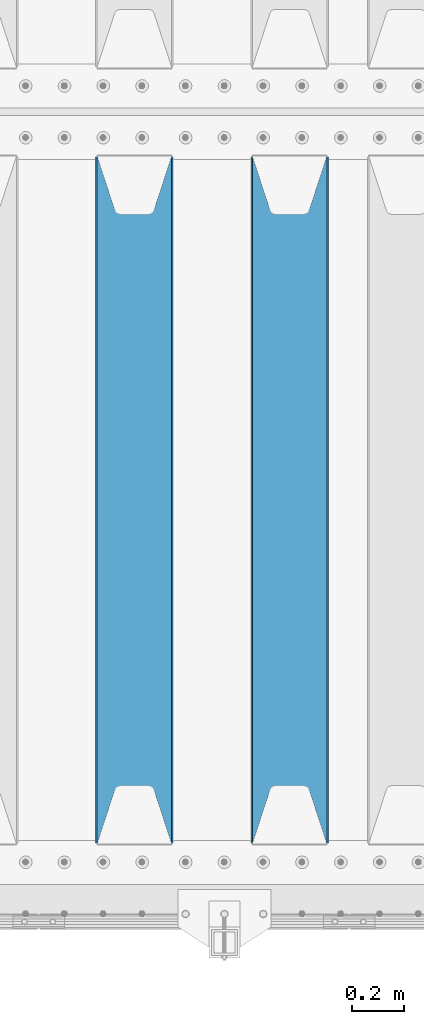
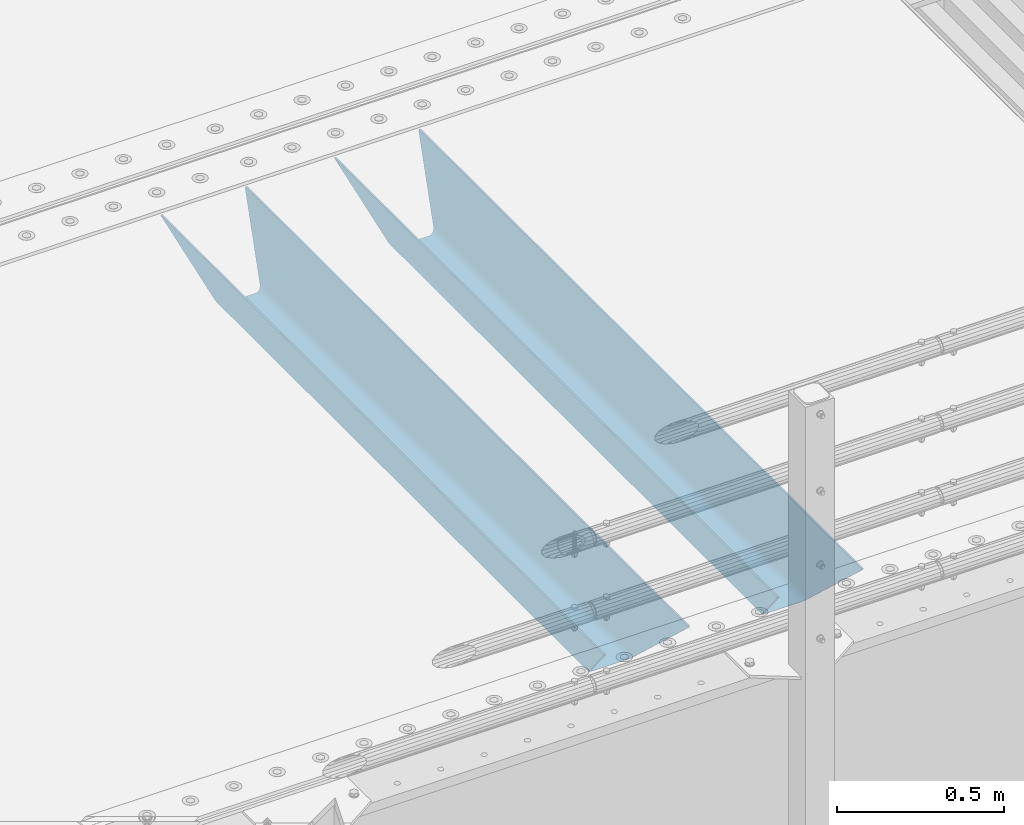
# One storey, part 140 of 270: 2 beams.
"""IFC2X3 building model written with IfcOpenShell, lengths in millimetres."""

import ifcopenshell
import ifcopenshell.guid

model = None  # the IFC model being written
_history = None  # IfcOwnerHistory: only IFC2X3 demands one
_inside = {}  # id of a spatial element -> (the spatial element, [elements in it])
_under = {}  # id of a project, library or spatial element -> (it, [spatial elements below it])
_declared = {}  # id of a project -> (the project, [libraries it declares])
_typed = {}  # id of a type object -> (the type object, [elements of that type])
_made_of = {}  # id of a material, layer set ... -> (it, [elements and type objects made of it])


def new_model(schema):
    """Start an empty IFC model of exactly this schema.

    Asked for "IFC4X3", IfcOpenShell would pick the latest addendum, in which some entities
    have other attributes; the version numbers below select the first issue.
    IFC2X3 requires an IfcOwnerHistory on every rooted entity: one is made here for all.
    """
    global model, _history
    if schema == "IFC4X3":
        model = ifcopenshell.file(schema_version=(4, 3, 0, 0))
    else:
        model = ifcopenshell.file(schema=schema)
    _inside.clear()
    _under.clear()
    _declared.clear()
    _typed.clear()
    _made_of.clear()
    _history = None
    if model.schema == "IFC2X3":
        org = make("IfcOrganization", Name="unknown")
        user = make(
            "IfcPersonAndOrganization",
            ThePerson=make("IfcPerson", FamilyName="unknown"),
            TheOrganization=org,
        )
        app = make(
            "IfcApplication",
            ApplicationDeveloper=org,
            Version="unknown",
            ApplicationFullName="unknown",
            ApplicationIdentifier="unknown",
        )
        _history = make(
            "IfcOwnerHistory",
            OwningUser=user,
            OwningApplication=app,
            ChangeAction="ADDED",
            CreationDate=0,
        )
    return model


def make(cls, **values):
    """One entity of the class cls with the attributes given. An attribute that is None is left unset."""
    return model.create_entity(
        cls, **{name: value for name, value in values.items() if value is not None}
    )


def rooted(cls, **values):
    """An entity with a GlobalId (a new one), such as an element, a storey or a relation."""
    return make(cls, GlobalId=ifcopenshell.guid.new(), OwnerHistory=_history, **values)


def si_unit(unit_type, name, prefix=None):
    """IfcSIUnit, for example si_unit("LENGTHUNIT", "METRE", prefix="MILLI")."""
    return make("IfcSIUnit", UnitType=unit_type, Prefix=prefix, Name=name)


def assignment(units):
    """IfcUnitAssignment: the units of a project."""
    return None if units is None else make("IfcUnitAssignment", Units=units)


def point(xyz):
    """IfcCartesianPoint."""
    return None if xyz is None else make("IfcCartesianPoint", Coordinates=xyz)


def direction(xyz):
    """IfcDirection."""
    return None if xyz is None else make("IfcDirection", DirectionRatios=xyz)


def frame(location, z_axis=None, x_axis=None):
    """IfcAxis2Placement3D, a coordinate frame: its origin and axes. An axis left out is left unset."""
    return make(
        "IfcAxis2Placement3D",
        Location=point(location),
        Axis=direction(z_axis),
        RefDirection=direction(x_axis),
    )


def origin_with_axes():
    """The frame at (0, 0, 0) with the z axis (0, 0, 1) and the x axis (1, 0, 0) written out."""
    return frame((0.0, 0.0, 0.0), z_axis=(0.0, 0.0, 1.0), x_axis=(1.0, 0.0, 0.0))


def place(relative_to, where):
    """IfcLocalPlacement: puts the frame where relative to a parent placement (None: the world)."""
    return make(
        "IfcLocalPlacement", PlacementRelTo=relative_to, RelativePlacement=where
    )


def context(
    kind, dimensions, precision=None, world=None, true_north=None, identifier=None
):
    """IfcGeometricRepresentationContext, for example the 3D "Model" context."""
    return make(
        "IfcGeometricRepresentationContext",
        ContextIdentifier=identifier,
        ContextType=kind,
        CoordinateSpaceDimension=dimensions,
        Precision=precision,
        WorldCoordinateSystem=world,
        TrueNorth=true_north,
    )


def subcontext(parent, identifier, kind, view, scale=None):
    """IfcGeometricRepresentationSubContext, for example "Body" below "Model"."""
    return make(
        "IfcGeometricRepresentationSubContext",
        ContextIdentifier=identifier,
        ContextType=kind,
        ParentContext=parent,
        TargetScale=scale,
        TargetView=view,
    )


def project(units=None, contexts=None):
    """IfcProject with its units and contexts."""
    return rooted(
        "IfcProject",
        Name="project",
        RepresentationContexts=contexts,
        UnitsInContext=assignment(units),
    )


def spatial(cls, under=None, at=None, **own):
    """A site, building, storey or space (cls), placed at a placement, below another one or the project."""
    s = rooted(cls, ObjectPlacement=at, **own)
    if under is not None:
        _under.setdefault(under.id(), (under, []))[1].append(s)
    return s


def faces_of(points, faces, orient=None, outer=None):
    """IfcFace entities. A face is a list of loops; a loop is a list of indices into points, from 0.

    orient and outer hold one flag for each loop. By default every Orientation is true, the
    first loop of a face is its IfcFaceOuterBound and the others are IfcFaceBound.
    """
    made = []
    for i, loops in enumerate(faces):
        bounds = []
        for j, loop in enumerate(loops):
            is_outer = j == 0 if outer is None else outer[i][j]
            bounds.append(
                make(
                    "IfcFaceOuterBound" if is_outer else "IfcFaceBound",
                    Bound=make("IfcPolyLoop", Polygon=[points[k] for k in loop]),
                    Orientation=True if orient is None else orient[i][j],
                )
            )
        made.append(make("IfcFace", Bounds=bounds))
    return made


def faceted_brep(points, faces, orient=None, outer=None, voids=None):
    """IfcFacetedBrep: a solid bounded by flat faces; with voids (closed shells), ...WithVoids."""
    shared = [point(p) for p in points]
    hull = make("IfcClosedShell", CfsFaces=faces_of(shared, faces, orient, outer))
    if voids is None:
        return make("IfcFacetedBrep", Outer=hull)
    return make(
        "IfcFacetedBrepWithVoids",
        Outer=hull,
        Voids=[
            make(cls, CfsFaces=faces_of(shared, fs, o, b)) for cls, fs, o, b in voids
        ],
    )


def shape(context_of_items, identifier, shape_type, items):
    """IfcShapeRepresentation: the items that make up one representation, for example the "Body"."""
    return make(
        "IfcShapeRepresentation",
        ContextOfItems=context_of_items,
        RepresentationIdentifier=identifier,
        RepresentationType=shape_type,
        Items=items,
    )


def material(Name=None, Category=None):
    """IfcMaterial."""
    return make("IfcMaterial", Name=Name, Category=Category)


def made_of(thing, what):
    """Note that an element or type object is made of a material, layer set ...; save() writes the relation."""
    if what is not None:
        _made_of.setdefault(what.id(), (what, []))[1].append(thing)
    return thing


def type_object(cls, material=None, **own):
    """A type object (cls), such as IfcWallType, which elements share."""
    return made_of(rooted(cls, **own), material)


def element(
    cls,
    number,
    at=None,
    inside=None,
    cuts=None,
    type_object=None,
    material=None,
    context=None,
    identifier="Body",
    shape_type=None,
    held_by="IfcProductDefinitionShape",
    body=None,
    shapes=None,
    **own,
):
    """One element of the class cls, such as IfcWall. Its Tag is "e" and its number.

    at: its placement. inside: the storey or other place that contains it. cuts: it is an
    opening in that element (IfcRelVoidsElement). A single representation is given by context,
    identifier, shape_type and body (its items); several are given by shapes. held_by: the class
    of the entity that holds the representations. save() writes the other relations.
    """
    e = rooted(cls, Tag="e%d" % number, ObjectPlacement=at, **own)
    if body is not None:
        shapes = [shape(context, identifier, shape_type, body)]
    if shapes is not None:
        e.Representation = make(held_by, Representations=shapes)
    if inside is not None:
        _inside.setdefault(inside.id(), (inside, []))[1].append(e)
    if cuts is not None:
        rooted(
            "IfcRelVoidsElement", RelatingBuildingElement=cuts, RelatedOpeningElement=e
        )
    if type_object is not None:
        _typed.setdefault(type_object.id(), (type_object, []))[1].append(e)
    return made_of(e, material)


def aggregate(whole, parts):
    """IfcRelAggregates: a whole, such as a stair, and the parts it consists of."""
    return rooted("IfcRelAggregates", RelatingObject=whole, RelatedObjects=parts)


def save(model, path):
    """Write the relations noted so far, then the file.

    IfcRelAggregates (storeys below a building ...), IfcRelContainedInSpatialStructure (elements
    in a storey), IfcRelDefinesByType, IfcRelAssociatesMaterial and IfcRelDeclares: one each for
    every whole, place, type object, material and project.
    """
    for whole, parts in _under.values():
        aggregate(whole, parts)
    for where, things in _inside.values():
        rooted(
            "IfcRelContainedInSpatialStructure",
            RelatedElements=things,
            RelatingStructure=where,
        )
    for kind, things in _typed.values():
        rooted("IfcRelDefinesByType", RelatedObjects=things, RelatingType=kind)
    for what, things in _made_of.values():
        rooted("IfcRelAssociatesMaterial", RelatedObjects=things, RelatingMaterial=what)
    for by, libraries in _declared.values():
        rooted("IfcRelDeclares", RelatingContext=by, RelatedDefinitions=libraries)
    model.write(path)


model = new_model("IFC2X3")

# Units and contexts
model_context = context("Model", 3, precision=1e-05, world=origin_with_axes())
body_context = subcontext(model_context, "Body", "Model", "MODEL_VIEW")
ifc_project = project(units=[si_unit("LENGTHUNIT", "METRE", prefix="MILLI"), si_unit("AREAUNIT", "SQUARE_METRE"), si_unit("VOLUMEUNIT", "CUBIC_METRE"), si_unit("MASSUNIT", "GRAM", prefix="KILO"), si_unit("TIMEUNIT", "SECOND"), si_unit("PLANEANGLEUNIT", "RADIAN"), si_unit("SOLIDANGLEUNIT", "STERADIAN"), si_unit("THERMODYNAMICTEMPERATUREUNIT", "DEGREE_CELSIUS"), si_unit("LUMINOUSINTENSITYUNIT", "LUMEN")], contexts=[model_context])

# Site, building, storey
site_placement = place(None, origin_with_axes())
site = spatial("IfcSite", under=ifc_project, at=site_placement, CompositionType="ELEMENT")
building_placement = place(site_placement, origin_with_axes())
building = spatial("IfcBuilding", under=site, at=building_placement, Name="Standard", CompositionType="ELEMENT")
storey_placement = place(building_placement, origin_with_axes())
storey = spatial("IfcBuildingStorey", under=building, at=storey_placement, Name="Undefined", CompositionType="ELEMENT", Elevation=0.0)

# Beams
ifc_material = material(Name="STEEL/S355N")
beam_type = type_object("IfcBeamType", PredefinedType="NOTDEFINED")
beam_1_placement = place(storey_placement, frame((18670.0, -23825.0, -115.0), z_axis=(0.0, 0.0, 1.0), x_axis=(0.0, 1.0, 0.0)))
element("IfcBeam", 1, at=beam_1_placement, inside=storey, type_object=beam_type, material=ifc_material, context=body_context, shape_type="Brep", body=[
    faceted_brep([(0.0, 150.0, 115.0), (0.0, 143.689999999999, 115.0), (2650.00000000297, 143.689999999999, 115.0), (2650.00000000297, 150.0, 115.0), (2650.00000000297, 142.059565218398, 110.000000003096), (2650.00000000297, 148.3695652184, 110.000000003096), (2441.90079219209, -80.1103600731112, -98.0992078077845), (2437.7588105432, -77.5672621345584, -102.241189456673), (2434.06523489747, -74.4080125315522, -105.934765102404), (2430.9108609509, -70.710272125576, -109.089139048974), (2428.37322971128, -66.5649389910068, -111.626770288588), (2426.51472138055, -62.0739139532889, -113.485278619323), (2425.38102192092, -57.3475956567672, -114.618978078955), (2424.99999999987, -52.5021667386536, -115.0), (2424.99999999987, 52.5021667386536, -115.0), (2425.38102192092, 57.3475956567672, -114.618978078955), (2426.51472138055, 62.0739139532889, -113.485278619323), (2428.37322971128, 66.5649389910068, -111.626770288588), (2430.9108609509, 70.710272125576, -109.089139048974), (2434.06523489747, 74.4080125315522, -105.934765102404), (2437.7588105432, 77.5672621345584, -102.241189456673), (2441.90079219209, 80.1103600731112, -98.0992078077846), (2446.38936140511, 81.9747917625791, -93.6106385947584), (2448.2494850041, 76.2713538057251, -91.7505149957729), (2444.62967112263, 74.76777986261, -95.3703288772456), (2441.28936334126, 72.7168944282894, -98.710636658607), (2438.31067330439, 70.1691124903846, -101.689326695487), (2435.76682334747, 67.1870637758839, -104.233176652398), (2433.72034654133, 63.8440531834895, -106.279653458539), (2432.22154950042, 60.222258798236, -107.778450499454), (2431.30727574265, 56.4107117849089, -108.692724257221), (2430.99999999987, 52.5031078186876, -109.0), (2430.99999999987, -52.5031078186876, -109.0), (2431.30727574265, -56.4107117849089, -108.692724257221), (2432.22154950042, -60.222258798236, -107.778450499454), (2433.72034654133, -63.8440531834895, -106.279653458539), (2435.76682334747, -67.1870637758839, -104.233176652398), (2438.31067330438, -70.1691124903846, -101.689326695487), (2441.28936334126, -72.7168944282894, -98.7106366586071), (2444.62967112263, -74.76777986261, -95.3703288772457), (2448.2494850041, -76.2713538057251, -91.7505149957729), (2650.00000000297, -142.059565218398, 110.000000003096), (2650.00000000297, -148.3695652184, 110.000000003096), (2446.38936140511, -81.9747917625791, -93.6106385947584), (2650.00000000297, -143.689999999999, 115.0), (2650.00000000297, -150.0, 115.0), (0.0, -143.689999999999, 115.0), (0.0, -150.0, 115.0), (0.0, -148.369565218261, 110.000000002672), (203.610638597431, -81.9747917625791, -93.6106385947584), (208.099207810457, -80.1103600731112, -98.0992078077845), (212.241189459342, -77.5672621345584, -102.241189456673), (215.934765105078, -74.4080125315522, -105.934765102404), (219.089139051644, -70.710272125576, -109.089139048974), (221.626770291259, -66.5649389910068, -111.626770288588), (223.485278621993, -62.0739139532889, -113.485278619323), (224.618978081628, -57.3475956567672, -114.618978078955), (225.00000000267, -52.5021667386536, -115.0), (225.00000000267, 52.5021667386536, -115.0), (224.618978081628, 57.3475956567672, -114.618978078955), (223.485278621993, 62.0739139532889, -113.485278619323), (221.626770291259, 66.5649389910068, -111.626770288588), (219.089139051644, 70.710272125576, -109.089139048974), (215.934765105078, 74.4080125315522, -105.934765102404), (212.241189459342, 77.5672621345584, -102.241189456673), (208.099207810457, 80.1103600731112, -98.0992078077846), (203.610638597431, 81.9747917625791, -93.6106385947584), (0.0, 148.369565218261, 110.000000002672), (0.0, 142.05956521826, 110.000000002672), (201.750514998446, 76.2713538057251, -91.7505149957729), (205.370328879915, 74.76777986261, -95.3703288772456), (208.710636661279, 72.7168944282894, -98.710636658607), (211.689326698157, 70.1691124903846, -101.689326695487), (214.233176655071, 67.1870637758839, -104.233176652398), (216.27965346121, 63.8440531834895, -106.279653458539), (217.778450502126, 60.222258798236, -107.778450499454), (218.692724259894, 56.4107117849089, -108.692724257221), (219.00000000267, 52.5031078186876, -109.0), (219.00000000267, -52.5031078186876, -109.0), (218.692724259894, -56.4107117849089, -108.692724257221), (217.778450502123, -60.222258798236, -107.778450499454), (216.27965346121, -63.8440531834895, -106.279653458539), (214.233176655071, -67.1870637758839, -104.233176652398), (211.689326698157, -70.1691124903846, -101.689326695487), (208.710636661279, -72.7168944282894, -98.7106366586071), (205.370328879915, -74.76777986261, -95.3703288772457), (201.750514998446, -76.2713538057251, -91.7505149957729), (0.0, -142.05956521826, 110.000000002672)], [[[0, 1, 2, 3]], [[3, 2, 4, 5]], [[6, 7, 8, 9, 10, 11, 12, 13, 14, 15, 16, 17, 18, 19, 20, 21, 22, 5, 4, 23, 24, 25, 26, 27, 28, 29, 30, 31, 32, 33, 34, 35, 36, 37, 38, 39, 40, 41, 42, 43]], [[44, 45, 42, 41]], [[46, 47, 45, 44]], [[43, 42, 45, 47, 48, 49]], [[6, 43, 49, 50]], [[7, 6, 50, 51]], [[8, 7, 51, 52]], [[9, 8, 52, 53]], [[10, 9, 53, 54]], [[11, 10, 54, 55]], [[12, 11, 55, 56]], [[13, 12, 56, 57]], [[14, 13, 57, 58]], [[15, 14, 58, 59]], [[16, 15, 59, 60]], [[17, 16, 60, 61]], [[18, 17, 61, 62]], [[19, 18, 62, 63]], [[20, 19, 63, 64]], [[21, 20, 64, 65]], [[22, 21, 65, 66]], [[0, 3, 5, 22, 66, 67]], [[1, 0, 67, 68]], [[23, 4, 2, 1, 68, 69]], [[24, 23, 69, 70]], [[25, 24, 70, 71]], [[26, 25, 71, 72]], [[27, 26, 72, 73]], [[28, 27, 73, 74]], [[29, 28, 74, 75]], [[30, 29, 75, 76]], [[31, 30, 76, 77]], [[32, 31, 77, 78]], [[33, 32, 78, 79]], [[34, 33, 79, 80]], [[35, 34, 80, 81]], [[36, 35, 81, 82]], [[37, 36, 82, 83]], [[38, 37, 83, 84]], [[39, 38, 84, 85]], [[40, 39, 85, 86]], [[46, 44, 41, 40, 86, 87]], [[47, 46, 87, 48]], [[86, 85, 84, 83, 82, 81, 80, 79, 78, 77, 76, 75, 74, 73, 72, 71, 70, 69, 68, 67, 66, 65, 64, 63, 62, 61, 60, 59, 58, 57, 56, 55, 54, 53, 52, 51, 50, 49, 48, 87]]]),
])
beam_2_placement = place(storey_placement, frame((18070.0, -23825.0, -115.0), z_axis=(0.0, 0.0, 1.0), x_axis=(0.0, 1.0, 0.0)))
element("IfcBeam", 2, at=beam_2_placement, inside=storey, type_object=beam_type, material=ifc_material, context=body_context, shape_type="Brep", body=[
    faceted_brep([(0.0, 150.0, 115.0), (0.0, 143.689999999999, 115.0), (2650.00000000297, 143.689999999999, 115.0), (2650.00000000297, 150.0, 115.0), (2650.00000000297, 142.059565218398, 110.000000003096), (2650.00000000297, 148.3695652184, 110.000000003096), (2441.90079219209, -80.1103600731112, -98.0992078077845), (2437.7588105432, -77.5672621345584, -102.241189456673), (2434.06523489747, -74.4080125315522, -105.934765102404), (2430.9108609509, -70.710272125576, -109.089139048974), (2428.37322971128, -66.5649389910068, -111.626770288588), (2426.51472138055, -62.0739139532889, -113.485278619323), (2425.38102192092, -57.3475956567672, -114.618978078955), (2424.99999999987, -52.5021667386536, -115.0), (2424.99999999987, 52.5021667386536, -115.0), (2425.38102192092, 57.3475956567672, -114.618978078955), (2426.51472138055, 62.0739139532889, -113.485278619323), (2428.37322971128, 66.5649389910068, -111.626770288588), (2430.9108609509, 70.710272125576, -109.089139048974), (2434.06523489747, 74.4080125315522, -105.934765102404), (2437.7588105432, 77.5672621345584, -102.241189456673), (2441.90079219209, 80.1103600731112, -98.0992078077846), (2446.38936140511, 81.9747917625791, -93.6106385947584), (2448.2494850041, 76.2713538057251, -91.7505149957729), (2444.62967112263, 74.76777986261, -95.3703288772456), (2441.28936334126, 72.7168944282894, -98.710636658607), (2438.31067330439, 70.1691124903846, -101.689326695487), (2435.76682334747, 67.1870637758839, -104.233176652398), (2433.72034654133, 63.8440531834895, -106.279653458539), (2432.22154950042, 60.222258798236, -107.778450499454), (2431.30727574265, 56.4107117849089, -108.692724257221), (2430.99999999987, 52.5031078186876, -109.0), (2430.99999999987, -52.5031078186876, -109.0), (2431.30727574265, -56.4107117849089, -108.692724257221), (2432.22154950042, -60.222258798236, -107.778450499454), (2433.72034654133, -63.8440531834895, -106.279653458539), (2435.76682334747, -67.1870637758839, -104.233176652398), (2438.31067330438, -70.1691124903846, -101.689326695487), (2441.28936334126, -72.7168944282894, -98.7106366586071), (2444.62967112263, -74.76777986261, -95.3703288772457), (2448.2494850041, -76.2713538057251, -91.7505149957729), (2650.00000000297, -142.059565218398, 110.000000003096), (2650.00000000297, -148.3695652184, 110.000000003096), (2446.38936140511, -81.9747917625791, -93.6106385947584), (2650.00000000297, -143.689999999999, 115.0), (2650.00000000297, -150.0, 115.0), (0.0, -143.689999999999, 115.0), (0.0, -150.0, 115.0), (0.0, -148.369565218261, 110.000000002672), (203.610638597431, -81.9747917625791, -93.6106385947584), (208.099207810457, -80.1103600731112, -98.0992078077845), (212.241189459342, -77.5672621345584, -102.241189456673), (215.934765105078, -74.4080125315522, -105.934765102404), (219.089139051644, -70.710272125576, -109.089139048974), (221.626770291259, -66.5649389910068, -111.626770288588), (223.485278621993, -62.0739139532889, -113.485278619323), (224.618978081628, -57.3475956567672, -114.618978078955), (225.00000000267, -52.5021667386536, -115.0), (225.00000000267, 52.5021667386536, -115.0), (224.618978081628, 57.3475956567672, -114.618978078955), (223.485278621993, 62.0739139532889, -113.485278619323), (221.626770291259, 66.5649389910068, -111.626770288588), (219.089139051644, 70.710272125576, -109.089139048974), (215.934765105078, 74.4080125315522, -105.934765102404), (212.241189459342, 77.5672621345584, -102.241189456673), (208.099207810457, 80.1103600731112, -98.0992078077846), (203.610638597431, 81.9747917625791, -93.6106385947584), (0.0, 148.369565218261, 110.000000002672), (0.0, 142.05956521826, 110.000000002672), (201.750514998446, 76.2713538057251, -91.7505149957729), (205.370328879915, 74.76777986261, -95.3703288772456), (208.710636661279, 72.7168944282894, -98.710636658607), (211.689326698157, 70.1691124903846, -101.689326695487), (214.233176655071, 67.1870637758839, -104.233176652398), (216.27965346121, 63.8440531834895, -106.279653458539), (217.778450502126, 60.222258798236, -107.778450499454), (218.692724259894, 56.4107117849089, -108.692724257221), (219.00000000267, 52.5031078186876, -109.0), (219.00000000267, -52.5031078186876, -109.0), (218.692724259894, -56.4107117849089, -108.692724257221), (217.778450502123, -60.222258798236, -107.778450499454), (216.27965346121, -63.8440531834895, -106.279653458539), (214.233176655071, -67.1870637758839, -104.233176652398), (211.689326698157, -70.1691124903846, -101.689326695487), (208.710636661279, -72.7168944282894, -98.7106366586071), (205.370328879915, -74.76777986261, -95.3703288772457), (201.750514998446, -76.2713538057251, -91.7505149957729), (0.0, -142.05956521826, 110.000000002672)], [[[0, 1, 2, 3]], [[3, 2, 4, 5]], [[6, 7, 8, 9, 10, 11, 12, 13, 14, 15, 16, 17, 18, 19, 20, 21, 22, 5, 4, 23, 24, 25, 26, 27, 28, 29, 30, 31, 32, 33, 34, 35, 36, 37, 38, 39, 40, 41, 42, 43]], [[44, 45, 42, 41]], [[46, 47, 45, 44]], [[43, 42, 45, 47, 48, 49]], [[6, 43, 49, 50]], [[7, 6, 50, 51]], [[8, 7, 51, 52]], [[9, 8, 52, 53]], [[10, 9, 53, 54]], [[11, 10, 54, 55]], [[12, 11, 55, 56]], [[13, 12, 56, 57]], [[14, 13, 57, 58]], [[15, 14, 58, 59]], [[16, 15, 59, 60]], [[17, 16, 60, 61]], [[18, 17, 61, 62]], [[19, 18, 62, 63]], [[20, 19, 63, 64]], [[21, 20, 64, 65]], [[22, 21, 65, 66]], [[0, 3, 5, 22, 66, 67]], [[1, 0, 67, 68]], [[23, 4, 2, 1, 68, 69]], [[24, 23, 69, 70]], [[25, 24, 70, 71]], [[26, 25, 71, 72]], [[27, 26, 72, 73]], [[28, 27, 73, 74]], [[29, 28, 74, 75]], [[30, 29, 75, 76]], [[31, 30, 76, 77]], [[32, 31, 77, 78]], [[33, 32, 78, 79]], [[34, 33, 79, 80]], [[35, 34, 80, 81]], [[36, 35, 81, 82]], [[37, 36, 82, 83]], [[38, 37, 83, 84]], [[39, 38, 84, 85]], [[40, 39, 85, 86]], [[46, 44, 41, 40, 86, 87]], [[47, 46, 87, 48]], [[86, 85, 84, 83, 82, 81, 80, 79, 78, 77, 76, 75, 74, 73, 72, 71, 70, 69, 68, 67, 66, 65, 64, 63, 62, 61, 60, 59, 58, 57, 56, 55, 54, 53, 52, 51, 50, 49, 48, 87]]]),
])

save(model, "model.ifc")
